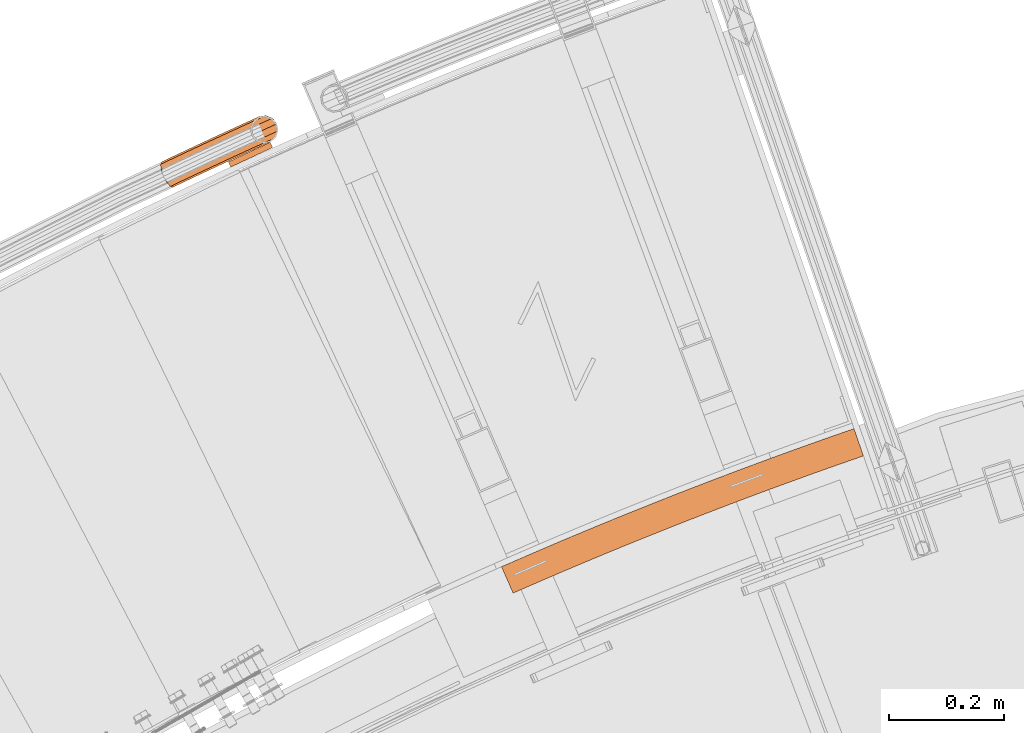
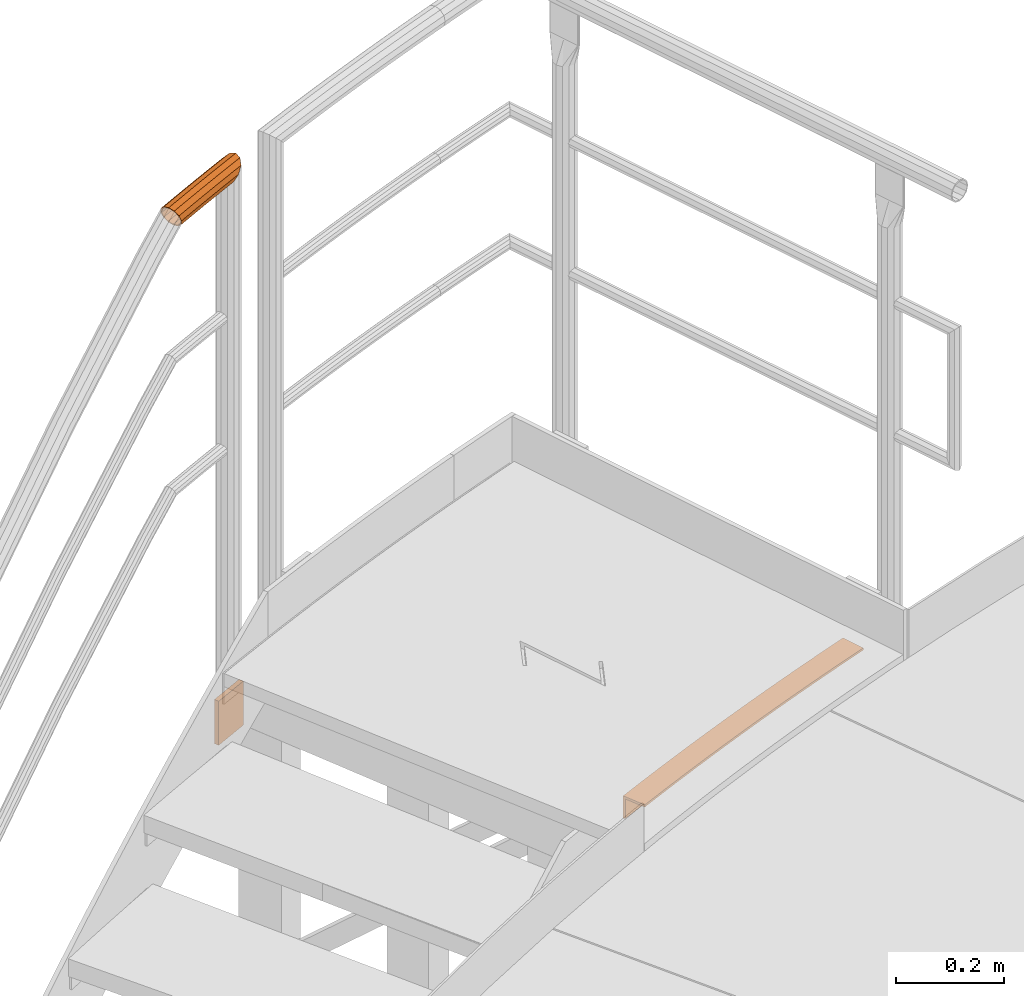
# One storey, part 84 of 126: 3 proxies.
"""IFC2X3 building model written with IfcOpenShell, lengths in millimetres."""

from ifc_helpers import new_model, si_unit, origin, origin_with_axes, place, context, project, spatial, faceted_brep, material, element, save


model = new_model("IFC2X3")

# Units and contexts
context_of_model_1 = context(None, 3, precision=0.1, world=origin())
context_of_model_2 = context(None, 3, precision=0.1, world=origin())
ifc_project = project(units=[si_unit("LENGTHUNIT", "METRE", prefix="MILLI"), si_unit("AREAUNIT", "SQUARE_METRE", prefix="CENTI"), si_unit("VOLUMEUNIT", "CUBIC_METRE", prefix="CENTI"), si_unit("MASSUNIT", "GRAM", prefix="KILO")], contexts=[context_of_model_1, context_of_model_2])

# Site, building, storey
site_placement = place(None, origin_with_axes())
site = spatial("IfcSite", under=ifc_project, at=site_placement, CompositionType="ELEMENT")
building_placement = place(site_placement, origin_with_axes())
building = spatial("IfcBuilding", under=site, at=building_placement, CompositionType="ELEMENT")
storey_placement = place(building_placement, origin_with_axes())
storey = spatial("IfcBuildingStorey", under=building, at=storey_placement, CompositionType="ELEMENT")

# Proxies
ifc_material = material(Name="S235JRG2")
proxy_1_placement = place(storey_placement, origin_with_axes())
element("IfcBuildingElementProxy", 1, at=proxy_1_placement, inside=storey, material=ifc_material, Name="HANDLAUF", context=context_of_model_2, shape_type="Brep", body=[
    faceted_brep([(4782.2845, 15332.648, 11055.0), (4782.2845, 15332.648, 11005.0), (4784.2972, 15328.071, 11005.0), (4784.2972, 15328.071, 11050.0), (4802.4115, 15286.878, 11050.0), (4802.4115, 15286.878, 11055.0), (4788.2887, 15335.288, 11055.0), (4788.2887, 15335.288, 11005.0), (4790.2977, 15330.709, 11005.0), (4790.2977, 15330.709, 11050.0), (4808.3782, 15289.501, 11050.0), (4808.3782, 15289.501, 11055.0), (4800.3058, 15340.549, 11055.0), (4800.3058, 15340.549, 11005.0), (4802.3073, 15335.967, 11005.0), (4802.3073, 15335.967, 11050.0), (4820.3202, 15294.729, 11050.0), (4820.3202, 15294.729, 11055.0), (4812.3315, 15345.79, 11055.0), (4812.3315, 15345.79, 11005.0), (4814.3255, 15341.205, 11005.0), (4814.3255, 15341.205, 11050.0), (4832.2708, 15299.938, 11050.0), (4832.2708, 15299.938, 11055.0), (4824.3658, 15351.012, 11055.0), (4824.3658, 15351.012, 11005.0), (4826.3522, 15346.423, 11005.0), (4826.3522, 15346.423, 11050.0), (4844.2299, 15305.127, 11050.0), (4844.2299, 15305.127, 11055.0), (4836.4086, 15356.214, 11055.0), (4836.4086, 15356.214, 11005.0), (4838.3875, 15351.622, 11005.0), (4838.3875, 15351.622, 11050.0), (4856.1975, 15310.296, 11050.0), (4856.1975, 15310.296, 11055.0), (4848.4599, 15361.396, 11055.0), (4848.4599, 15361.396, 11005.0), (4850.4313, 15356.8, 11005.0), (4850.4313, 15356.8, 11050.0), (4868.1736, 15315.446, 11050.0), (4868.1736, 15315.446, 11055.0), (4860.5198, 15366.558, 11055.0), (4860.5198, 15366.558, 11005.0), (4862.4836, 15361.96, 11005.0), (4862.4836, 15361.96, 11050.0), (4880.1581, 15320.576, 11050.0), (4880.1581, 15320.576, 11055.0), (4872.588, 15371.7, 11055.0), (4872.588, 15371.7, 11005.0), (4874.5443, 15367.099, 11005.0), (4874.5443, 15367.099, 11050.0), (4892.1509, 15325.686, 11050.0), (4892.1509, 15325.686, 11055.0), (4884.6647, 15376.823, 11055.0), (4884.6647, 15376.823, 11005.0), (4886.6134, 15372.218, 11005.0), (4886.6134, 15372.218, 11050.0), (4904.1522, 15330.777, 11050.0), (4904.1522, 15330.777, 11055.0), (4896.7497, 15381.926, 11055.0), (4896.7497, 15381.926, 11005.0), (4898.6909, 15377.318, 11005.0), (4898.6909, 15377.318, 11050.0), (4916.1617, 15335.848, 11050.0), (4916.1617, 15335.848, 11055.0), (4908.8431, 15387.009, 11055.0), (4908.8431, 15387.009, 11005.0), (4910.7767, 15382.398, 11005.0), (4910.7767, 15382.398, 11050.0), (4928.1796, 15340.899, 11050.0), (4928.1796, 15340.899, 11055.0), (4920.9448, 15392.072, 11055.0), (4920.9448, 15392.072, 11005.0), (4922.8709, 15387.458, 11005.0), (4922.8709, 15387.458, 11050.0), (4940.2057, 15345.931, 11050.0), (4940.2057, 15345.931, 11055.0), (4933.0548, 15397.116, 11055.0), (4933.0548, 15397.116, 11005.0), (4934.9733, 15392.499, 11005.0), (4934.9733, 15392.499, 11050.0), (4952.24, 15350.943, 11050.0), (4952.24, 15350.943, 11055.0), (4945.173, 15402.139, 11055.0), (4945.173, 15402.139, 11005.0), (4947.0839, 15397.519, 11005.0), (4947.0839, 15397.519, 11050.0), (4964.2826, 15355.935, 11050.0), (4964.2826, 15355.935, 11055.0), (4957.2994, 15407.143, 11055.0), (4957.2994, 15407.143, 11005.0), (4959.2028, 15402.52, 11005.0), (4959.2028, 15402.52, 11050.0), (4976.3333, 15360.908, 11050.0), (4976.3333, 15360.908, 11055.0), (4969.4341, 15412.127, 11055.0), (4969.4341, 15412.127, 11005.0), (4971.3299, 15407.5, 11005.0), (4971.3299, 15407.5, 11050.0), (4988.3921, 15365.861, 11050.0), (4988.3921, 15365.861, 11055.0), (4981.5768, 15417.091, 11055.0), (4981.5768, 15417.091, 11005.0), (4983.4651, 15412.461, 11005.0), (4983.4651, 15412.461, 11050.0), (5000.459, 15370.793, 11050.0), (5000.459, 15370.793, 11055.0), (4993.7277, 15422.035, 11055.0), (4993.7277, 15422.035, 11005.0), (4995.6084, 15417.402, 11005.0), (4995.6084, 15417.402, 11050.0), (5012.534, 15375.707, 11050.0), (5012.534, 15375.707, 11055.0), (5005.8867, 15426.959, 11055.0), (5005.8867, 15426.959, 11005.0), (5007.7598, 15422.323, 11005.0), (5007.7598, 15422.323, 11050.0), (5024.6171, 15380.6, 11050.0), (5024.6171, 15380.6, 11055.0), (5018.0538, 15431.863, 11055.0), (5018.0538, 15431.863, 11005.0), (5019.9192, 15427.224, 11005.0), (5019.9192, 15427.224, 11050.0), (5036.7081, 15385.474, 11050.0), (5036.7081, 15385.474, 11055.0), (5030.2288, 15436.748, 11055.0), (5030.2288, 15436.748, 11005.0), (5032.0866, 15432.106, 11005.0), (5032.0866, 15432.106, 11050.0), (5048.8071, 15390.327, 11050.0), (5048.8071, 15390.327, 11055.0), (5042.4119, 15441.612, 11055.0), (5042.4119, 15441.612, 11005.0), (5044.2621, 15436.967, 11005.0), (5044.2621, 15436.967, 11050.0), (5060.9141, 15395.161, 11050.0), (5060.9141, 15395.161, 11055.0), (5054.6029, 15446.456, 11055.0), (5054.6029, 15446.456, 11005.0), (5056.4455, 15441.808, 11005.0), (5056.4455, 15441.808, 11050.0), (5073.0289, 15399.975, 11050.0), (5073.0289, 15399.975, 11055.0), (5066.8018, 15451.281, 11055.0), (5066.8018, 15451.281, 11005.0), (5068.6368, 15446.63, 11005.0), (5068.6368, 15446.63, 11050.0), (5085.1516, 15404.77, 11050.0), (5085.1516, 15404.77, 11055.0), (5079.0086, 15456.085, 11055.0), (5079.0086, 15456.085, 11005.0), (5080.836, 15451.431, 11005.0), (5080.836, 15451.431, 11050.0), (5097.2822, 15409.544, 11050.0), (5097.2822, 15409.544, 11055.0), (5091.2233, 15460.869, 11055.0), (5091.2233, 15460.869, 11005.0), (5093.043, 15456.212, 11005.0), (5093.043, 15456.212, 11050.0), (5109.4206, 15414.298, 11050.0), (5109.4206, 15414.298, 11055.0), (5103.4458, 15465.634, 11055.0), (5103.4458, 15465.634, 11005.0), (5105.2579, 15460.974, 11005.0), (5105.2579, 15460.974, 11050.0), (5121.5667, 15419.033, 11050.0), (5121.5667, 15419.033, 11055.0), (5115.676, 15470.378, 11055.0), (5115.676, 15470.378, 11005.0), (5117.4805, 15465.715, 11005.0), (5117.4805, 15465.715, 11050.0), (5133.7206, 15423.748, 11050.0), (5133.7206, 15423.748, 11055.0), (5127.9141, 15475.102, 11055.0), (5127.9141, 15475.102, 11005.0), (5129.7109, 15470.436, 11005.0), (5129.7109, 15470.436, 11050.0), (5145.8822, 15428.442, 11050.0), (5145.8822, 15428.442, 11055.0), (5140.1598, 15479.806, 11055.0), (5140.1598, 15479.806, 11005.0), (5141.949, 15475.137, 11005.0), (5141.949, 15475.137, 11050.0), (5158.0515, 15433.117, 11050.0), (5158.0515, 15433.117, 11055.0), (5152.4133, 15484.491, 11055.0), (5152.4133, 15484.491, 11005.0), (5154.1948, 15479.819, 11005.0), (5154.1948, 15479.819, 11050.0), (5170.2284, 15437.772, 11050.0), (5170.2284, 15437.772, 11055.0), (5164.6744, 15489.155, 11055.0), (5164.6744, 15489.155, 11005.0), (5166.4483, 15484.48, 11005.0), (5166.4483, 15484.48, 11050.0), (5182.413, 15442.407, 11050.0), (5182.413, 15442.407, 11055.0), (5176.9432, 15493.798, 11055.0), (5176.9432, 15493.798, 11005.0), (5178.7094, 15489.121, 11005.0), (5178.7094, 15489.121, 11050.0), (5194.6051, 15447.022, 11050.0), (5194.6051, 15447.022, 11055.0), (5189.2195, 15498.422, 11055.0), (5189.2195, 15498.422, 11005.0), (5190.978, 15493.742, 11005.0), (5190.978, 15493.742, 11050.0), (5206.8047, 15451.617, 11050.0), (5206.8047, 15451.617, 11055.0), (5201.5034, 15503.026, 11055.0), (5201.5034, 15503.026, 11005.0), (5203.2543, 15498.342, 11005.0), (5203.2543, 15498.342, 11050.0), (5219.0119, 15456.192, 11050.0), (5219.0119, 15456.192, 11055.0), (5213.7948, 15507.609, 11055.0), (5213.7948, 15507.609, 11005.0), (5215.538, 15502.923, 11005.0), (5215.538, 15502.923, 11050.0), (5231.2266, 15460.746, 11050.0), (5231.2266, 15460.746, 11055.0), (5226.0938, 15512.173, 11055.0), (5226.0938, 15512.173, 11005.0), (5227.8292, 15507.484, 11005.0), (5227.8292, 15507.484, 11050.0), (5243.4487, 15465.281, 11050.0), (5243.4487, 15465.281, 11055.0), (5238.4001, 15516.716, 11055.0), (5238.4001, 15516.716, 11005.0), (5240.1279, 15512.024, 11005.0), (5240.1279, 15512.024, 11050.0), (5255.6782, 15469.796, 11050.0), (5255.6782, 15469.796, 11055.0), (5250.714, 15521.239, 11055.0), (5250.714, 15521.239, 11005.0), (5252.4341, 15516.544, 11005.0), (5252.4341, 15516.544, 11050.0), (5267.9151, 15474.291, 11050.0), (5267.9151, 15474.291, 11055.0), (5263.0352, 15525.742, 11055.0), (5263.0352, 15525.742, 11005.0), (5264.7476, 15521.044, 11005.0), (5264.7476, 15521.044, 11050.0), (5280.1593, 15478.766, 11050.0), (5280.1593, 15478.766, 11055.0), (5275.3637, 15530.225, 11055.0), (5275.3637, 15530.225, 11005.0), (5277.0685, 15525.524, 11005.0), (5277.0685, 15525.524, 11050.0), (5292.4109, 15483.22, 11050.0), (5292.4109, 15483.22, 11055.0), (5287.6996, 15534.687, 11055.0), (5287.6996, 15534.687, 11005.0), (5289.3966, 15529.984, 11005.0), (5289.3966, 15529.984, 11050.0), (5304.6697, 15487.655, 11050.0), (5304.6697, 15487.655, 11055.0), (5300.0428, 15539.129, 11055.0), (5300.0428, 15539.129, 11005.0), (5301.7321, 15534.423, 11005.0), (5301.7321, 15534.423, 11050.0), (5316.9358, 15492.07, 11050.0), (5316.9358, 15492.07, 11055.0), (5312.3933, 15543.551, 11055.0), (5312.3933, 15543.551, 11005.0), (5314.0749, 15538.843, 11005.0), (5314.0749, 15538.843, 11050.0), (5329.2092, 15496.464, 11050.0), (5329.2092, 15496.464, 11055.0), (5324.751, 15547.953, 11055.0), (5324.751, 15547.953, 11005.0), (5326.4249, 15543.242, 11005.0), (5326.4249, 15543.242, 11050.0), (5341.4897, 15500.838, 11050.0), (5341.4897, 15500.838, 11055.0), (5337.1159, 15552.335, 11055.0), (5337.1159, 15552.335, 11005.0), (5338.782, 15547.62, 11005.0), (5338.782, 15547.62, 11050.0), (5353.7773, 15505.192, 11050.0), (5353.7773, 15505.192, 11055.0), (5349.4879, 15556.696, 11055.0), (5349.4879, 15556.696, 11005.0), (5351.1463, 15551.979, 11005.0), (5351.1463, 15551.979, 11050.0), (5366.0721, 15509.526, 11050.0), (5366.0721, 15509.526, 11055.0), (5361.8671, 15561.037, 11055.0), (5361.8671, 15561.037, 11005.0), (5363.5178, 15556.317, 11005.0), (5363.5178, 15556.317, 11050.0), (5378.374, 15513.84, 11050.0), (5378.374, 15513.84, 11055.0), (5374.2534, 15565.358, 11055.0), (5374.2534, 15565.358, 11005.0), (5375.8963, 15560.635, 11005.0), (5375.8963, 15560.635, 11050.0), (5390.6829, 15518.134, 11050.0), (5390.6829, 15518.134, 11055.0), (5386.6467, 15569.658, 11055.0), (5386.6467, 15569.658, 11005.0), (5388.2819, 15564.933, 11005.0), (5388.2819, 15564.933, 11050.0), (5402.9988, 15522.407, 11050.0), (5402.9988, 15522.407, 11055.0), (5392.8469, 15571.798, 11055.0), (5392.8469, 15571.798, 11005.0), (5394.4782, 15567.072, 11005.0), (5394.4782, 15567.072, 11050.0), (5409.1603, 15524.534, 11050.0), (5409.1603, 15524.534, 11055.0)], [[[0, 1, 2, 3, 4, 5]], [[0, 6, 7, 1]], [[1, 7, 8, 2]], [[2, 8, 9, 3]], [[3, 9, 10, 4]], [[4, 10, 11, 5]], [[5, 11, 6, 0]], [[6, 12, 13, 7]], [[7, 13, 14, 8]], [[8, 14, 15, 9]], [[9, 15, 16, 10]], [[10, 16, 17, 11]], [[11, 17, 12, 6]], [[12, 18, 19, 13]], [[13, 19, 20, 14]], [[14, 20, 21, 15]], [[15, 21, 22, 16]], [[16, 22, 23, 17]], [[17, 23, 18, 12]], [[18, 24, 25, 19]], [[19, 25, 26, 20]], [[20, 26, 27, 21]], [[21, 27, 28, 22]], [[22, 28, 29, 23]], [[23, 29, 24, 18]], [[24, 30, 31, 25]], [[25, 31, 32, 26]], [[26, 32, 33, 27]], [[27, 33, 34, 28]], [[28, 34, 35, 29]], [[29, 35, 30, 24]], [[30, 36, 37, 31]], [[31, 37, 38, 32]], [[32, 38, 39, 33]], [[33, 39, 40, 34]], [[34, 40, 41, 35]], [[35, 41, 36, 30]], [[36, 42, 43, 37]], [[37, 43, 44, 38]], [[38, 44, 45, 39]], [[39, 45, 46, 40]], [[40, 46, 47, 41]], [[41, 47, 42, 36]], [[42, 48, 49, 43]], [[43, 49, 50, 44]], [[44, 50, 51, 45]], [[45, 51, 52, 46]], [[46, 52, 53, 47]], [[47, 53, 48, 42]], [[48, 54, 55, 49]], [[49, 55, 56, 50]], [[50, 56, 57, 51]], [[51, 57, 58, 52]], [[52, 58, 59, 53]], [[53, 59, 54, 48]], [[54, 60, 61, 55]], [[55, 61, 62, 56]], [[56, 62, 63, 57]], [[57, 63, 64, 58]], [[58, 64, 65, 59]], [[59, 65, 60, 54]], [[60, 66, 67, 61]], [[61, 67, 68, 62]], [[62, 68, 69, 63]], [[63, 69, 70, 64]], [[64, 70, 71, 65]], [[65, 71, 66, 60]], [[66, 72, 73, 67]], [[67, 73, 74, 68]], [[68, 74, 75, 69]], [[69, 75, 76, 70]], [[70, 76, 77, 71]], [[71, 77, 72, 66]], [[72, 78, 79, 73]], [[73, 79, 80, 74]], [[74, 80, 81, 75]], [[75, 81, 82, 76]], [[76, 82, 83, 77]], [[77, 83, 78, 72]], [[78, 84, 85, 79]], [[79, 85, 86, 80]], [[80, 86, 87, 81]], [[81, 87, 88, 82]], [[82, 88, 89, 83]], [[83, 89, 84, 78]], [[84, 90, 91, 85]], [[85, 91, 92, 86]], [[86, 92, 93, 87]], [[87, 93, 94, 88]], [[88, 94, 95, 89]], [[89, 95, 90, 84]], [[90, 96, 97, 91]], [[91, 97, 98, 92]], [[92, 98, 99, 93]], [[93, 99, 100, 94]], [[94, 100, 101, 95]], [[95, 101, 96, 90]], [[96, 102, 103, 97]], [[97, 103, 104, 98]], [[98, 104, 105, 99]], [[99, 105, 106, 100]], [[100, 106, 107, 101]], [[101, 107, 102, 96]], [[102, 108, 109, 103]], [[103, 109, 110, 104]], [[104, 110, 111, 105]], [[105, 111, 112, 106]], [[106, 112, 113, 107]], [[107, 113, 108, 102]], [[108, 114, 115, 109]], [[109, 115, 116, 110]], [[110, 116, 117, 111]], [[111, 117, 118, 112]], [[112, 118, 119, 113]], [[113, 119, 114, 108]], [[114, 120, 121, 115]], [[115, 121, 122, 116]], [[116, 122, 123, 117]], [[117, 123, 124, 118]], [[118, 124, 125, 119]], [[119, 125, 120, 114]], [[120, 126, 127, 121]], [[121, 127, 128, 122]], [[122, 128, 129, 123]], [[123, 129, 130, 124]], [[124, 130, 131, 125]], [[125, 131, 126, 120]], [[126, 132, 133, 127]], [[127, 133, 134, 128]], [[128, 134, 135, 129]], [[129, 135, 136, 130]], [[130, 136, 137, 131]], [[131, 137, 132, 126]], [[132, 138, 139, 133]], [[133, 139, 140, 134]], [[134, 140, 141, 135]], [[135, 141, 142, 136]], [[136, 142, 143, 137]], [[137, 143, 138, 132]], [[138, 144, 145, 139]], [[139, 145, 146, 140]], [[140, 146, 147, 141]], [[141, 147, 148, 142]], [[142, 148, 149, 143]], [[143, 149, 144, 138]], [[144, 150, 151, 145]], [[145, 151, 152, 146]], [[146, 152, 153, 147]], [[147, 153, 154, 148]], [[148, 154, 155, 149]], [[149, 155, 150, 144]], [[150, 156, 157, 151]], [[151, 157, 158, 152]], [[152, 158, 159, 153]], [[153, 159, 160, 154]], [[154, 160, 161, 155]], [[155, 161, 156, 150]], [[156, 162, 163, 157]], [[157, 163, 164, 158]], [[158, 164, 165, 159]], [[159, 165, 166, 160]], [[160, 166, 167, 161]], [[161, 167, 162, 156]], [[162, 168, 169, 163]], [[163, 169, 170, 164]], [[164, 170, 171, 165]], [[165, 171, 172, 166]], [[166, 172, 173, 167]], [[167, 173, 168, 162]], [[168, 174, 175, 169]], [[169, 175, 176, 170]], [[170, 176, 177, 171]], [[171, 177, 178, 172]], [[172, 178, 179, 173]], [[173, 179, 174, 168]], [[174, 180, 181, 175]], [[175, 181, 182, 176]], [[176, 182, 183, 177]], [[177, 183, 184, 178]], [[178, 184, 185, 179]], [[179, 185, 180, 174]], [[180, 186, 187, 181]], [[181, 187, 188, 182]], [[182, 188, 189, 183]], [[183, 189, 190, 184]], [[184, 190, 191, 185]], [[185, 191, 186, 180]], [[186, 192, 193, 187]], [[187, 193, 194, 188]], [[188, 194, 195, 189]], [[189, 195, 196, 190]], [[190, 196, 197, 191]], [[191, 197, 192, 186]], [[192, 198, 199, 193]], [[193, 199, 200, 194]], [[194, 200, 201, 195]], [[195, 201, 202, 196]], [[196, 202, 203, 197]], [[197, 203, 198, 192]], [[198, 204, 205, 199]], [[199, 205, 206, 200]], [[200, 206, 207, 201]], [[201, 207, 208, 202]], [[202, 208, 209, 203]], [[203, 209, 204, 198]], [[204, 210, 211, 205]], [[205, 211, 212, 206]], [[206, 212, 213, 207]], [[207, 213, 214, 208]], [[208, 214, 215, 209]], [[209, 215, 210, 204]], [[210, 216, 217, 211]], [[211, 217, 218, 212]], [[212, 218, 219, 213]], [[213, 219, 220, 214]], [[214, 220, 221, 215]], [[215, 221, 216, 210]], [[216, 222, 223, 217]], [[217, 223, 224, 218]], [[218, 224, 225, 219]], [[219, 225, 226, 220]], [[220, 226, 227, 221]], [[221, 227, 222, 216]], [[222, 228, 229, 223]], [[223, 229, 230, 224]], [[224, 230, 231, 225]], [[225, 231, 232, 226]], [[226, 232, 233, 227]], [[227, 233, 228, 222]], [[228, 234, 235, 229]], [[229, 235, 236, 230]], [[230, 236, 237, 231]], [[231, 237, 238, 232]], [[232, 238, 239, 233]], [[233, 239, 234, 228]], [[234, 240, 241, 235]], [[235, 241, 242, 236]], [[236, 242, 243, 237]], [[237, 243, 244, 238]], [[238, 244, 245, 239]], [[239, 245, 240, 234]], [[240, 246, 247, 241]], [[241, 247, 248, 242]], [[242, 248, 249, 243]], [[243, 249, 250, 244]], [[244, 250, 251, 245]], [[245, 251, 246, 240]], [[246, 252, 253, 247]], [[247, 253, 254, 248]], [[248, 254, 255, 249]], [[249, 255, 256, 250]], [[250, 256, 257, 251]], [[251, 257, 252, 246]], [[252, 258, 259, 253]], [[253, 259, 260, 254]], [[254, 260, 261, 255]], [[255, 261, 262, 256]], [[256, 262, 263, 257]], [[257, 263, 258, 252]], [[258, 264, 265, 259]], [[259, 265, 266, 260]], [[260, 266, 267, 261]], [[261, 267, 268, 262]], [[262, 268, 269, 263]], [[263, 269, 264, 258]], [[264, 270, 271, 265]], [[265, 271, 272, 266]], [[266, 272, 273, 267]], [[267, 273, 274, 268]], [[268, 274, 275, 269]], [[269, 275, 270, 264]], [[270, 276, 277, 271]], [[271, 277, 278, 272]], [[272, 278, 279, 273]], [[273, 279, 280, 274]], [[274, 280, 281, 275]], [[275, 281, 276, 270]], [[276, 282, 283, 277]], [[277, 283, 284, 278]], [[278, 284, 285, 279]], [[279, 285, 286, 280]], [[280, 286, 287, 281]], [[281, 287, 282, 276]], [[282, 288, 289, 283]], [[283, 289, 290, 284]], [[284, 290, 291, 285]], [[285, 291, 292, 286]], [[286, 292, 293, 287]], [[287, 293, 288, 282]], [[288, 294, 295, 289]], [[289, 295, 296, 290]], [[290, 296, 297, 291]], [[291, 297, 298, 292]], [[292, 298, 299, 293]], [[293, 299, 294, 288]], [[294, 300, 301, 295]], [[295, 301, 302, 296]], [[296, 302, 303, 297]], [[297, 303, 304, 298]], [[298, 304, 305, 299]], [[299, 305, 300, 294]], [[300, 306, 307, 301]], [[301, 307, 308, 302]], [[302, 308, 309, 303]], [[303, 309, 310, 304]], [[304, 310, 311, 305]], [[305, 311, 306, 300]], [[306, 311, 310, 309, 308, 307]]]),
])
proxy_2_placement = place(storey_placement, origin_with_axes())
element("IfcBuildingElementProxy", 2, at=proxy_2_placement, inside=storey, material=ifc_material, context=context_of_model_2, shape_type="Brep", body=[
    faceted_brep([(4381.7106, 16067.804, 10913.95), (4385.9386, 16058.742, 10913.95), (4313.4405, 16024.918, 10913.95), (4309.2126, 16033.98, 10913.95), (4381.7106, 16067.804, 11013.95), (4309.2126, 16033.98, 11013.95), (4313.4405, 16024.918, 11013.95), (4385.9386, 16058.742, 11013.95)], [[[0, 1, 2, 3]], [[4, 5, 6, 7]], [[0, 4, 7, 1]], [[1, 7, 6, 2]], [[0, 3, 5, 4]], [[2, 6, 5, 3]]]),
])
proxy_3_placement = place(storey_placement, origin_with_axes())
element("IfcBuildingElementProxy", 3, at=proxy_3_placement, inside=storey, material=ifc_material, Name="HANDLAUF", context=context_of_model_2, shape_type="Brep", body=[
    faceted_brep([(4390.4495, 16085.247, 12181.915), (4392.523, 16080.632, 12176.855), (4395.1743, 16087.36, 12181.915), (4393.4304, 16099.807, 12185.15), (4385.5011, 16096.262, 12185.15), (4385.7779, 16109.612, 12181.915), (4380.5528, 16107.276, 12181.915), (4378.1532, 16112.617, 12176.059), (4381.065, 16106.136, 12179.749), (4379.5852, 16109.43, 12176.138), (4384.2873, 16107.577, 12179.749), (4391.1476, 16098.786, 12182.65), (4385.5011, 16096.262, 12182.65), (4392.711, 16087.628, 12179.749), (4389.9372, 16086.387, 12179.749), (4391.1545, 16083.678, 12176.779), (4347.3259, 16105.527, 12161.0), (4362.0031, 16112.152, 12161.0), (4352.2529, 16104.201, 12148.925), (4348.6621, 16102.58, 12148.925), (4350.2472, 16099.085, 12145.087), (4365.9368, 16064.485, 12148.925), (4364.7309, 16067.144, 12146.005), (4368.5293, 16065.655, 12148.925), (4380.7974, 16067.643, 12161.0), (4367.273, 16061.538, 12161.0), (4390.5476, 16075.593, 12173.075), (4365.9368, 16064.485, 12173.075), (4362.2862, 16072.535, 12181.915), (4357.2995, 16083.532, 12185.15), (4352.3127, 16094.53, 12181.915), (4374.2712, 16114.139, 12173.075), (4348.6621, 16102.58, 12173.075), (4348.3584, 16103.25, 12161.0), (4362.9759, 16109.848, 12161.0), (4373.974, 16111.629, 12171.825), (4349.5563, 16100.608, 12171.825), (4352.8289, 16093.391, 12179.749), (4357.2995, 16083.532, 12182.65), (4361.77, 16073.674, 12179.749), (4388.5655, 16077.074, 12171.825), (4365.0427, 16066.457, 12171.825), (4379.8247, 16069.946, 12161.0), (4366.2406, 16063.815, 12161.0), (4368.8265, 16068.165, 12150.175), (4365.0427, 16066.457, 12150.175), (4363.2827, 16070.338, 12145.913), (4349.5563, 16100.608, 12150.175), (4351.6215, 16096.054, 12145.174), (4354.2351, 16102.72, 12150.175), (4320.4387, 16089.723, 12148.925), (4319.0922, 16092.665, 12161.0), (4347.6403, 16092.401, 12140.085), (4324.1173, 16081.685, 12140.085), (4349.3938, 16079.931, 12136.85), (4329.1424, 16070.705, 12136.85), (4357.0383, 16070.145, 12140.085), (4334.1676, 16059.725, 12140.085), (4337.8462, 16051.688, 12148.925), (4339.1927, 16048.746, 12161.0), (4337.8462, 16051.688, 12173.075), (4334.1676, 16059.725, 12181.915), (4329.1424, 16070.705, 12185.15), (4324.1173, 16081.685, 12181.915), (4320.4387, 16089.723, 12173.075), (4321.3397, 16087.754, 12171.825), (4320.1326, 16090.391, 12161.0), (4324.6375, 16080.548, 12179.749), (4329.1424, 16070.705, 12182.65), (4333.6474, 16060.862, 12179.749), (4336.9452, 16053.656, 12171.825), (4338.1523, 16051.019, 12161.0), (4336.9452, 16053.656, 12150.175), (4358.5229, 16072.195, 12142.251), (4333.6474, 16060.862, 12142.251), (4351.6697, 16080.968, 12139.35), (4329.1424, 16070.705, 12139.35), (4350.0977, 16092.147, 12142.251), (4324.6375, 16080.548, 12142.251), (4321.3397, 16087.754, 12150.175), (4292.2602, 16076.767, 12148.925), (4290.9035, 16079.704, 12161.0), (4295.9669, 16068.742, 12140.085), (4301.0303, 16057.78, 12136.85), (4306.0938, 16046.817, 12140.085), (4309.8005, 16038.793, 12148.925), (4311.1572, 16035.855, 12161.0), (4309.8005, 16038.793, 12173.075), (4306.0938, 16046.817, 12181.915), (4301.0303, 16057.78, 12185.15), (4295.9669, 16068.742, 12181.915), (4292.2602, 16076.767, 12173.075), (4293.1681, 16074.801, 12171.825), (4291.9518, 16077.434, 12161.0), (4296.4911, 16067.607, 12179.749), (4301.0303, 16057.78, 12182.65), (4305.5696, 16047.952, 12179.749), (4308.8926, 16040.758, 12171.825), (4310.1089, 16038.125, 12161.0), (4308.8926, 16040.758, 12150.175), (4305.5696, 16047.952, 12142.251), (4301.0303, 16057.78, 12139.35), (4296.4911, 16067.607, 12142.251), (4293.1681, 16074.801, 12150.175), (4264.1272, 16063.712, 12148.925), (4262.7602, 16066.645, 12161.0), (4267.8619, 16055.7, 12140.085), (4272.9636, 16044.756, 12136.85), (4278.0652, 16033.812, 12140.085), (4281.7999, 16025.8, 12148.925), (4283.1669, 16022.867, 12161.0), (4281.7999, 16025.8, 12173.075), (4278.0652, 16033.812, 12181.915), (4272.9636, 16044.756, 12185.15), (4267.8619, 16055.7, 12181.915), (4264.1272, 16063.712, 12173.075), (4265.042, 16061.75, 12171.825), (4263.8165, 16064.379, 12161.0), (4268.39, 16054.567, 12179.749), (4272.9636, 16044.756, 12182.65), (4277.5371, 16034.945, 12179.749), (4280.8852, 16027.762, 12171.825), (4282.1106, 16025.133, 12161.0), (4280.8852, 16027.762, 12150.175), (4277.5371, 16034.945, 12142.251), (4272.9636, 16044.756, 12139.35), (4268.39, 16054.567, 12142.251), (4265.042, 16061.75, 12150.175), (4236.0399, 16050.56, 12148.925), (4234.6627, 16053.487, 12161.0), (4239.8026, 16042.561, 12140.085), (4244.9424, 16031.635, 12136.85), (4250.0822, 16020.708, 12140.085), (4253.8448, 16012.709, 12148.925), (4255.2221, 16009.781, 12161.0), (4253.8448, 16012.709, 12173.075), (4250.0822, 16020.708, 12181.915), (4244.9424, 16031.635, 12185.15), (4239.8026, 16042.561, 12181.915), (4236.0399, 16050.56, 12173.075), (4236.9615, 16048.601, 12171.825), (4235.7269, 16051.225, 12161.0), (4240.3346, 16041.43, 12179.749), (4244.9424, 16031.635, 12182.65), (4249.5501, 16021.839, 12179.749), (4252.9233, 16014.668, 12171.825), (4254.1579, 16012.044, 12161.0), (4252.9233, 16014.668, 12150.175), (4249.5501, 16021.839, 12142.251), (4244.9424, 16031.635, 12139.35), (4240.3346, 16041.43, 12142.251), (4236.9615, 16048.601, 12150.175), (4207.9987, 16037.309, 12148.925), (4206.6113, 16040.232, 12161.0), (4211.7893, 16029.324, 12140.085), (4216.9672, 16018.415, 12136.85), (4222.1451, 16007.507, 12140.085), (4225.9357, 15999.521, 12148.925), (4227.3231, 15996.598, 12161.0), (4225.9357, 15999.521, 12173.075), (4222.1451, 16007.507, 12181.915), (4216.9672, 16018.415, 12185.15), (4211.7893, 16029.324, 12181.915), (4207.9987, 16037.309, 12173.075), (4208.9271, 16035.353, 12171.825), (4207.6833, 16037.974, 12161.0), (4212.3253, 16028.195, 12179.749), (4216.9672, 16018.415, 12182.65), (4221.6091, 16008.636, 12179.749), (4225.0072, 16001.477, 12171.825), (4226.251, 15998.857, 12161.0), (4225.0072, 16001.477, 12150.175), (4221.6091, 16008.636, 12142.251), (4216.9672, 16018.415, 12139.35), (4212.3253, 16028.195, 12142.251), (4208.9271, 16035.353, 12150.175), (4198.6996, 16032.875, 12148.925), (4193.9427, 16034.192, 12161.0), (4204.796, 16025.989, 12140.085), (4210.5984, 16015.379, 12136.85), (4214.5521, 16003.886, 12140.085), (4215.5976, 15994.592, 12148.925), (4213.4548, 15989.986, 12161.0), (4208.6979, 15991.302, 12173.075), (4202.6015, 15998.188, 12181.915), (4196.7991, 16008.799, 12185.15), (4192.8454, 16020.291, 12181.915), (4191.8, 16029.585, 12173.075), (4193.0317, 16027.774, 12171.825), (4194.9527, 16031.904, 12161.0), (4193.969, 16019.442, 12179.749), (4197.5133, 16009.139, 12182.65), (4202.7151, 15999.627, 12179.749), (4208.1804, 15993.454, 12171.825), (4212.4449, 15992.274, 12161.0), (4214.3658, 15996.403, 12150.175), (4213.4285, 16004.735, 12142.251), (4209.8842, 16015.038, 12139.35), (4204.6825, 16024.55, 12142.251), (4199.2171, 16030.724, 12150.175)], [[[0, 1, 2]], [[0, 2, 3, 4]], [[4, 3, 5, 6]], [[6, 5, 7]], [[8, 9, 10]], [[8, 10, 11, 12]], [[12, 11, 13, 14]], [[14, 13, 15]], [[16, 17, 18, 19]], [[19, 18, 20]], [[21, 22, 23]], [[21, 23, 24, 25]], [[25, 24, 26, 27]], [[0, 28, 27, 26, 1]], [[0, 4, 29, 28]], [[4, 6, 30, 29]], [[31, 32, 30, 6, 7]], [[16, 32, 31, 17]], [[33, 34, 35, 36]], [[35, 9, 8, 37, 36]], [[8, 12, 38, 37]], [[12, 14, 39, 38]], [[14, 15, 40, 41, 39]], [[41, 40, 42, 43]], [[43, 42, 44, 45]], [[45, 44, 46]], [[47, 48, 49]], [[33, 47, 49, 34]], [[16, 19, 50, 51]], [[19, 20, 52, 53, 50]], [[53, 52, 54, 55]], [[55, 54, 56, 57]], [[56, 22, 21, 58, 57]], [[21, 25, 59, 58]], [[25, 27, 60, 59]], [[27, 28, 61, 60]], [[28, 29, 62, 61]], [[29, 30, 63, 62]], [[30, 32, 64, 63]], [[32, 16, 51, 64]], [[33, 36, 65, 66]], [[36, 37, 67, 65]], [[37, 38, 68, 67]], [[38, 39, 69, 68]], [[39, 41, 70, 69]], [[41, 43, 71, 70]], [[43, 45, 72, 71]], [[73, 74, 72, 45, 46]], [[74, 73, 75, 76]], [[76, 75, 77, 78]], [[47, 79, 78, 77, 48]], [[47, 33, 66, 79]], [[51, 50, 80, 81]], [[50, 53, 82, 80]], [[53, 55, 83, 82]], [[55, 57, 84, 83]], [[57, 58, 85, 84]], [[58, 59, 86, 85]], [[59, 60, 87, 86]], [[60, 61, 88, 87]], [[61, 62, 89, 88]], [[62, 63, 90, 89]], [[63, 64, 91, 90]], [[64, 51, 81, 91]], [[66, 65, 92, 93]], [[65, 67, 94, 92]], [[67, 68, 95, 94]], [[68, 69, 96, 95]], [[69, 70, 97, 96]], [[70, 71, 98, 97]], [[71, 72, 99, 98]], [[72, 74, 100, 99]], [[74, 76, 101, 100]], [[76, 78, 102, 101]], [[78, 79, 103, 102]], [[79, 66, 93, 103]], [[81, 80, 104, 105]], [[80, 82, 106, 104]], [[82, 83, 107, 106]], [[83, 84, 108, 107]], [[84, 85, 109, 108]], [[85, 86, 110, 109]], [[86, 87, 111, 110]], [[87, 88, 112, 111]], [[88, 89, 113, 112]], [[89, 90, 114, 113]], [[90, 91, 115, 114]], [[91, 81, 105, 115]], [[93, 92, 116, 117]], [[92, 94, 118, 116]], [[94, 95, 119, 118]], [[95, 96, 120, 119]], [[96, 97, 121, 120]], [[97, 98, 122, 121]], [[98, 99, 123, 122]], [[99, 100, 124, 123]], [[100, 101, 125, 124]], [[101, 102, 126, 125]], [[102, 103, 127, 126]], [[103, 93, 117, 127]], [[105, 104, 128, 129]], [[104, 106, 130, 128]], [[106, 107, 131, 130]], [[107, 108, 132, 131]], [[108, 109, 133, 132]], [[109, 110, 134, 133]], [[110, 111, 135, 134]], [[111, 112, 136, 135]], [[112, 113, 137, 136]], [[113, 114, 138, 137]], [[114, 115, 139, 138]], [[115, 105, 129, 139]], [[117, 116, 140, 141]], [[116, 118, 142, 140]], [[118, 119, 143, 142]], [[119, 120, 144, 143]], [[120, 121, 145, 144]], [[121, 122, 146, 145]], [[122, 123, 147, 146]], [[123, 124, 148, 147]], [[124, 125, 149, 148]], [[125, 126, 150, 149]], [[126, 127, 151, 150]], [[127, 117, 141, 151]], [[129, 128, 152, 153]], [[128, 130, 154, 152]], [[130, 131, 155, 154]], [[131, 132, 156, 155]], [[132, 133, 157, 156]], [[133, 134, 158, 157]], [[134, 135, 159, 158]], [[135, 136, 160, 159]], [[136, 137, 161, 160]], [[137, 138, 162, 161]], [[138, 139, 163, 162]], [[139, 129, 153, 163]], [[141, 140, 164, 165]], [[140, 142, 166, 164]], [[142, 143, 167, 166]], [[143, 144, 168, 167]], [[144, 145, 169, 168]], [[145, 146, 170, 169]], [[146, 147, 171, 170]], [[147, 148, 172, 171]], [[148, 149, 173, 172]], [[149, 150, 174, 173]], [[150, 151, 175, 174]], [[151, 141, 165, 175]], [[152, 176, 177, 153]], [[152, 154, 178, 176]], [[154, 155, 179, 178]], [[155, 156, 180, 179]], [[156, 157, 181, 180]], [[157, 158, 182, 181]], [[158, 159, 183, 182]], [[159, 160, 184, 183]], [[160, 161, 185, 184]], [[161, 162, 186, 185]], [[162, 163, 187, 186]], [[153, 177, 187, 163]], [[164, 188, 189, 165]], [[164, 166, 190, 188]], [[166, 167, 191, 190]], [[167, 168, 192, 191]], [[168, 169, 193, 192]], [[169, 170, 194, 193]], [[170, 171, 195, 194]], [[171, 172, 196, 195]], [[172, 173, 197, 196]], [[173, 174, 198, 197]], [[174, 175, 199, 198]], [[165, 189, 199, 175]], [[17, 31, 7, 5, 3, 2, 1, 26, 24, 23, 22, 56, 54, 52, 20, 18], [10, 9, 35, 34, 49, 48, 77, 75, 73, 46, 44, 42, 40, 15, 13, 11]], [[185, 186, 187, 177, 176, 178, 179, 180, 181, 182, 183, 184], [188, 190, 191, 192, 193, 194, 195, 196, 197, 198, 199, 189]]]),
])

save(model, "model.ifc")
